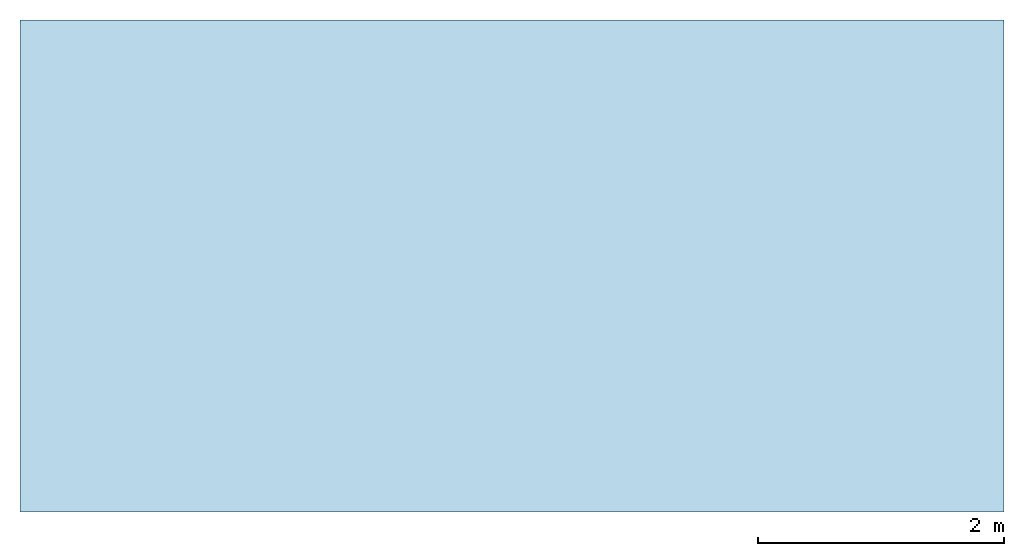
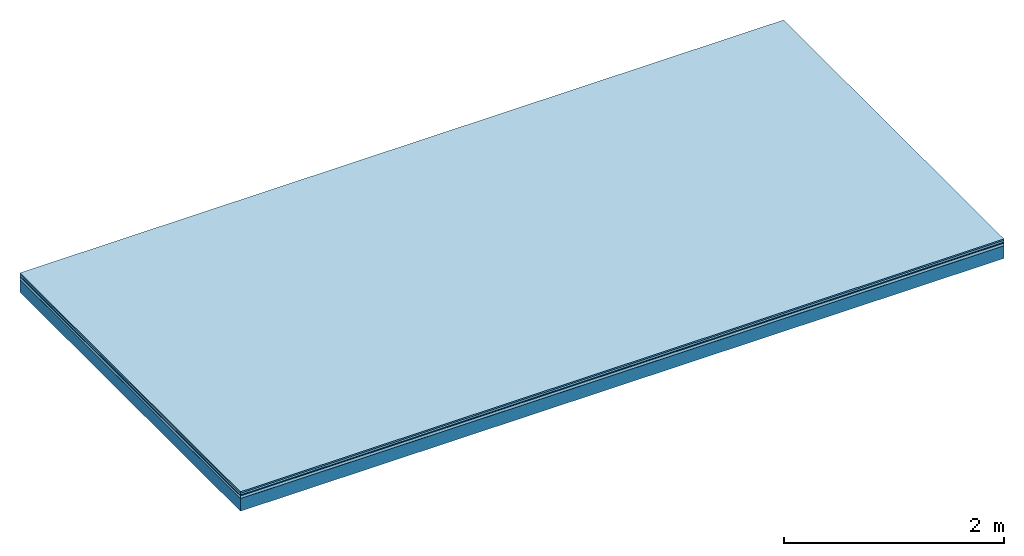
# One storey: 5 plates, 1 member, 1 element without a shape of its own.
"""IFC4 building model written with IfcOpenShell, lengths in metres."""

from ifc_helpers import new_model, si_unit, derived_unit, direction, frame, frame_2d, origin, origin_with_axes, place, context, project, spatial, rectangle, extrude, material, layer, layer_set, type_object, element, aggregate, save


model = new_model("IFC4")

# Units and contexts
plan_context = context("Plan", 3, precision=1e-05, world=origin(), true_north=direction((0.0, 1.0)))
model_context = context("Model", 3, precision=1e-05, world=origin(), true_north=direction((0.0, 1.0)))
ifc_project = project(units=[si_unit("LENGTHUNIT", "METRE"), derived_unit("SOUNDPRESSUREUNIT", [(si_unit("PRESSUREUNIT", "PASCAL", prefix="MICRO"), 0)]), si_unit("ENERGYUNIT", "JOULE", prefix="MEGA"), si_unit("MASSUNIT", "GRAM", prefix="KILO"), derived_unit("THERMALTRANSMITTANCEUNIT", [(si_unit("POWERUNIT", "WATT"), 1), (si_unit("AREAUNIT", "SQUARE_METRE"), -1), (si_unit("THERMODYNAMICTEMPERATUREUNIT", "KELVIN"), -1)]), derived_unit("AREADENSITYUNIT", [(si_unit("MASSUNIT", "GRAM", prefix="KILO"), 1), (si_unit("AREAUNIT", "SQUARE_METRE"), -1)]), derived_unit("USERDEFINED", [(si_unit("ENERGYUNIT", "JOULE", prefix="MEGA"), 1), (si_unit("AREAUNIT", "SQUARE_METRE"), -1)])], contexts=[plan_context, model_context])

# Site, building, storey
site = spatial("IfcSite", under=ifc_project)
building_placement = place(None, origin())
building = spatial("IfcBuilding", under=site, at=building_placement)
storey_placement = place(building_placement, origin())
storey = spatial("IfcBuildingStorey", under=building, at=storey_placement)

# Slab, member, plates
ifc_material_1 = material(Category="11.013")
ifc_layer_1 = layer(ifc_material_1, 0.015, Name="Flooring")
ifc_material_2 = material(Category="03.007")
ifc_layer_2 = layer(ifc_material_2, 0.02, Name="On-material")
ifc_material_3 = material(Name="Wood fiber generic product", Category="10.009")
ifc_layer_3 = layer(ifc_material_3, 0.01, Name="Impact sound insulation")
ifc_material_4 = material(Name="with broken")
ifc_layer_4 = layer(ifc_material_4, 0.03, Name="on Supporting structure")
ifc_material_5 = material(Name="protection", Category="09.007")
ifc_layer_5 = layer(ifc_material_5, 0.0005, Name="Sub-floor")
ifc_material_6 = material(Name="no composite action")
ifc_layer_6 = layer(ifc_material_6, 0.0, Name="Bond")
ifc_layer_7 = layer(None, 0.14, Name="Supporting structure")
ifc_layer_set = layer_set([ifc_layer_1, ifc_layer_2, ifc_layer_3, ifc_layer_4, ifc_layer_5, ifc_layer_6, ifc_layer_7])
slab_type = type_object("IfcSlabType", Name="A2043", PredefinedType="NOTDEFINED", material=ifc_layer_set)
slab_placement = place(None, frame((0.0, 0.0, 0.0), z_axis=(0.0, 0.0, -1.0), x_axis=(1.0, 0.0, 0.0)))
slab = element("IfcSlab", 1, at=slab_placement, inside=storey, type_object=slab_type, material=ifc_layer_set, Name="Slab #1")
ifc_material_7 = material(Name="Solid timber panel")
member_placement = place(slab_placement, origin())
member = element("IfcMember", 2, at=member_placement, material=ifc_material_7, Name="Supporting structure", context=plan_context, shape_type="SweptSolid", body=[
    extrude(rectangle(XDim=1.0, YDim=0.14, at=frame_2d((0.5, 0.07), x_axis=(1.0, 0.0))), frame((0.0, 4.0, 0.0755), z_axis=(0.0, -1.0, 0.0), x_axis=(1.0, 0.0, 0.0)), (0.0, 0.0, 1.0), 4.0),
    extrude(rectangle(XDim=1.0, YDim=0.14, at=frame_2d((0.5, 0.07), x_axis=(1.0, 0.0))), frame((1.0, 4.0, 0.0755), z_axis=(0.0, -1.0, 0.0), x_axis=(1.0, 0.0, 0.0)), (0.0, 0.0, 1.0), 4.0),
    extrude(rectangle(XDim=1.0, YDim=0.14, at=frame_2d((0.5, 0.07), x_axis=(1.0, 0.0))), frame((2.0, 4.0, 0.0755), z_axis=(0.0, -1.0, 0.0), x_axis=(1.0, 0.0, 0.0)), (0.0, 0.0, 1.0), 4.0),
    extrude(rectangle(XDim=1.0, YDim=0.14, at=frame_2d((0.5, 0.07), x_axis=(1.0, 0.0))), frame((3.0, 4.0, 0.0755), z_axis=(0.0, -1.0, 0.0), x_axis=(1.0, 0.0, 0.0)), (0.0, 0.0, 1.0), 4.0),
    extrude(rectangle(XDim=1.0, YDim=0.14, at=frame_2d((0.5, 0.07), x_axis=(1.0, 0.0))), frame((4.0, 4.0, 0.0755), z_axis=(0.0, -1.0, 0.0), x_axis=(1.0, 0.0, 0.0)), (0.0, 0.0, 1.0), 4.0),
    extrude(rectangle(XDim=1.0, YDim=0.14, at=frame_2d((0.5, 0.07), x_axis=(1.0, 0.0))), frame((5.0, 4.0, 0.0755), z_axis=(0.0, -1.0, 0.0), x_axis=(1.0, 0.0, 0.0)), (0.0, 0.0, 1.0), 4.0),
    extrude(rectangle(XDim=1.0, YDim=0.14, at=frame_2d((0.5, 0.07), x_axis=(1.0, 0.0))), frame((6.0, 4.0, 0.0755), z_axis=(0.0, -1.0, 0.0), x_axis=(1.0, 0.0, 0.0)), (0.0, 0.0, 1.0), 4.0),
    extrude(rectangle(XDim=1.0, YDim=0.14, at=frame_2d((0.5, 0.07), x_axis=(1.0, 0.0))), frame((7.0, 4.0, 0.0755), z_axis=(0.0, -1.0, 0.0), x_axis=(1.0, 0.0, 0.0)), (0.0, 0.0, 1.0), 4.0),
])
plate_1_placement = place(slab_placement, origin())
plate_1 = element("IfcPlate", 3, at=plate_1_placement, material=ifc_material_1, Name="Flooring", context=plan_context, shape_type="SweptSolid", body=[
    extrude(rectangle(XDim=8.0, YDim=4.0, at=frame_2d((4.0, 2.0), x_axis=(1.0, 0.0))), origin_with_axes(), (0.0, 0.0, 1.0), 0.015),
])
plate_2_placement = place(slab_placement, origin())
plate_2 = element("IfcPlate", 4, at=plate_2_placement, material=ifc_material_2, Name="On-material", context=plan_context, shape_type="SweptSolid", body=[
    extrude(rectangle(XDim=8.0, YDim=4.0, at=frame_2d((4.0, 2.0), x_axis=(1.0, 0.0))), frame((0.0, 0.0, 0.015), z_axis=(0.0, 0.0, 1.0), x_axis=(1.0, 0.0, 0.0)), (0.0, 0.0, 1.0), 0.02),
])
plate_3_placement = place(slab_placement, origin())
plate_3 = element("IfcPlate", 5, at=plate_3_placement, material=ifc_material_3, Name="Impact sound insulation", context=plan_context, shape_type="SweptSolid", body=[
    extrude(rectangle(XDim=8.0, YDim=4.0, at=frame_2d((4.0, 2.0), x_axis=(1.0, 0.0))), frame((0.0, 0.0, 0.035), z_axis=(0.0, 0.0, 1.0), x_axis=(1.0, 0.0, 0.0)), (0.0, 0.0, 1.0), 0.01),
])
plate_4_placement = place(slab_placement, origin())
plate_4 = element("IfcPlate", 6, at=plate_4_placement, material=ifc_material_4, Name="on Supporting structure", context=plan_context, shape_type="SweptSolid", body=[
    extrude(rectangle(XDim=8.0, YDim=4.0, at=frame_2d((4.0, 2.0), x_axis=(1.0, 0.0))), frame((0.0, 0.0, 0.045), z_axis=(0.0, 0.0, 1.0), x_axis=(1.0, 0.0, 0.0)), (0.0, 0.0, 1.0), 0.03),
])
plate_5_placement = place(slab_placement, origin())
plate_5 = element("IfcPlate", 7, at=plate_5_placement, material=ifc_material_5, Name="Sub-floor", context=plan_context, shape_type="SweptSolid", body=[
    extrude(rectangle(XDim=8.0, YDim=4.0, at=frame_2d((4.0, 2.0), x_axis=(1.0, 0.0))), frame((0.0, 0.0, 0.075), z_axis=(0.0, 0.0, 1.0), x_axis=(1.0, 0.0, 0.0)), (0.0, 0.0, 1.0), 0.0005),
])
aggregate(slab, [plate_1, plate_2, plate_3, plate_4, plate_5, member])

save(model, "model.ifc")
